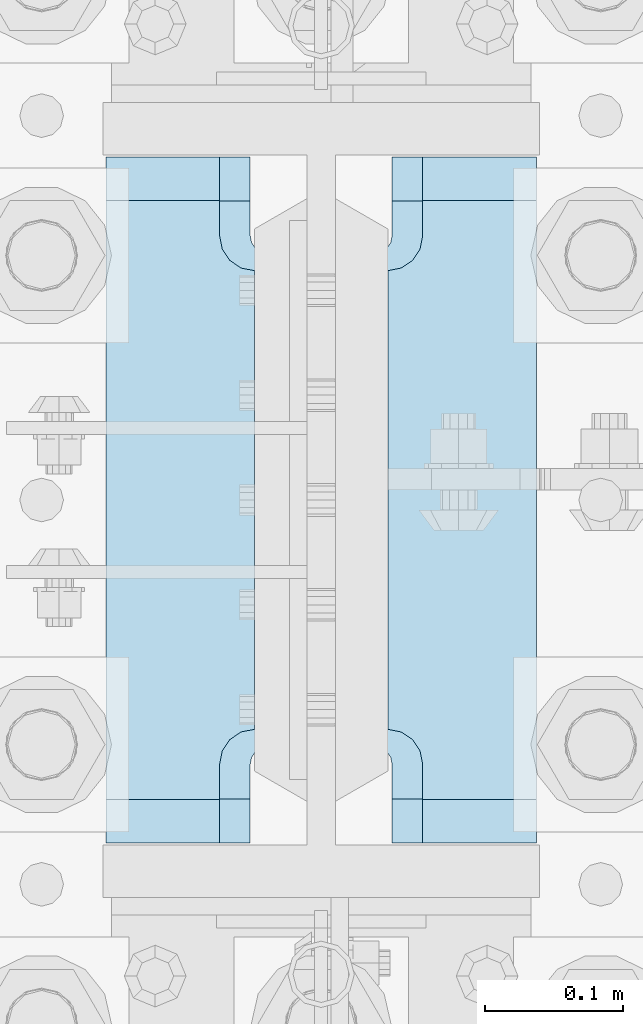
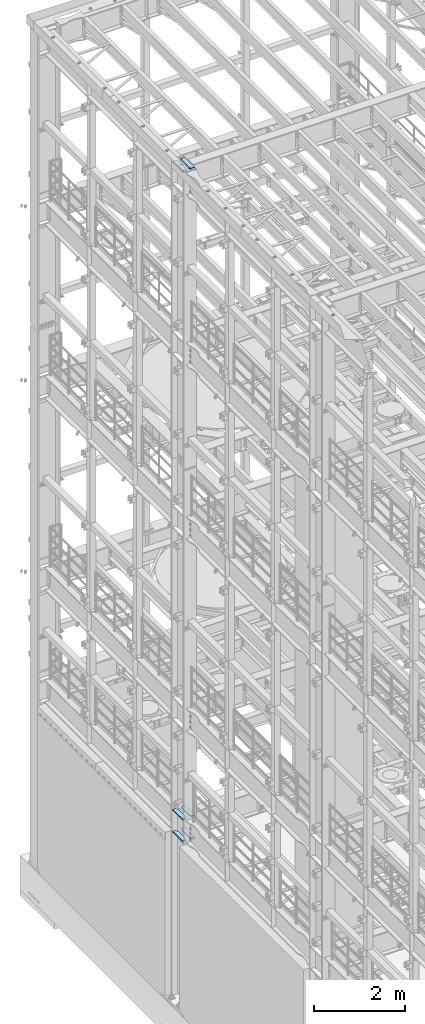
# One storey, part 1693 of 1876: 6 plates, 2 elements without a shape of their own.
"""IFC2X3 building model written with IfcOpenShell, lengths in millimetres."""

from ifc_helpers import new_model, si_unit, frame, origin_with_axes, place, context, subcontext, project, spatial, faceted_brep, material, type_object, element, aggregate, save


model = new_model("IFC2X3")

# Units and contexts
model_context = context("Model", 3, precision=1e-05, world=origin_with_axes())
body_context = subcontext(model_context, "Body", "Model", "MODEL_VIEW")
ifc_project = project(units=[si_unit("LENGTHUNIT", "METRE", prefix="MILLI"), si_unit("AREAUNIT", "SQUARE_METRE"), si_unit("VOLUMEUNIT", "CUBIC_METRE"), si_unit("MASSUNIT", "GRAM", prefix="KILO"), si_unit("TIMEUNIT", "SECOND"), si_unit("PLANEANGLEUNIT", "RADIAN"), si_unit("SOLIDANGLEUNIT", "STERADIAN"), si_unit("THERMODYNAMICTEMPERATUREUNIT", "DEGREE_CELSIUS"), si_unit("LUMINOUSINTENSITYUNIT", "LUMEN")], contexts=[model_context])

# Site, building, storey
site_placement = place(None, origin_with_axes())
site = spatial("IfcSite", under=ifc_project, at=site_placement, CompositionType="ELEMENT")
building_placement = place(site_placement, origin_with_axes())
building = spatial("IfcBuilding", under=site, at=building_placement, Name="Undefined", CompositionType="ELEMENT")
storey_placement = place(building_placement, origin_with_axes())
storey = spatial("IfcBuildingStorey", under=building, at=storey_placement, Name="Undefined", CompositionType="ELEMENT", Elevation=0.0)

# Assembly, plates
assembly_1_placement = place(storey_placement, origin_with_axes())
assembly_1 = element("IfcElementAssembly", 1, at=assembly_1_placement, inside=storey, Name="COLUMN", AssemblyPlace="NOTDEFINED", PredefinedType="RIGID_FRAME")
ifc_material = material(Name="STEEL/A572-50")
plate_type_1 = type_object("IfcPlateType", PredefinedType="NOTDEFINED")
plate_1_placement = place(assembly_1_placement, frame((-48.41875, 7370.7625, 4524.37501220703), z_axis=(0.0, 1.0, 0.0), x_axis=(-1.0, 0.0, 0.0)))
plate_1 = element("IfcPlate", 2, at=plate_1_placement, type_object=plate_type_1, material=ifc_material, Name="PLATE", context=body_context, shape_type="Brep", body=[
    faceted_brep([(107.949996948242, -15.875, 498.475006103516), (107.949996948242, 15.875, 467.025007631571), (25.3999996185303, 15.875, 467.025007631571), (25.3999996185303, -15.875, 498.475006103516), (23.4665397733561, -15.875, 431.604843634198), (25.3999996185303, -15.875, 441.325002670288), (25.3999996185303, 15.875, 441.325002670288), (23.4665397733561, 15.875, 431.604843634198), (17.9605119724001, -15.875, 423.36449069789), (17.9605119724001, 15.875, 423.36449069789), (9.72015903609281, -15.875, 417.858462896934), (9.72015903609281, 15.875, 417.858462896934), (0.0, -15.875, 415.925003051758), (0.0, 15.875, 415.925003051758), (0.0, -15.875, 82.5500030517578), (0.0, 15.875, 82.5500030517578), (9.72015903609099, -15.875, 80.616543206582), (9.72015903609099, 15.875, 80.616543206582), (17.9605119723983, -15.875, 75.1105154056258), (17.9605119723983, 15.875, 75.1105154056258), (23.4665397733552, -15.875, 66.8701624693183), (23.4665397733552, 15.875, 66.8701624693183), (25.3999996185303, -15.875, 57.1500034332275), (25.3999996185303, 15.875, 57.1500034332275), (25.3999996185303, 15.875, 31.449998471945), (25.3999996185303, -15.875, 0.0), (107.949996948242, 15.875, 31.449998471945), (107.949996948242, -15.875, 0.0)], [[[0, 1, 2, 3]], [[4, 5, 6, 7]], [[8, 4, 7, 9]], [[10, 8, 9, 11]], [[12, 10, 11, 13]], [[14, 12, 13, 15]], [[16, 14, 15, 17]], [[18, 16, 17, 19]], [[20, 18, 19, 21]], [[22, 20, 21, 23]], [[22, 23, 24, 25]], [[26, 27, 25, 24]], [[5, 4, 8, 10, 12, 14, 16, 18, 20, 22, 25, 27, 0, 3]], [[6, 5, 3, 2]], [[26, 24, 23, 21, 19, 17, 15, 13, 11, 9, 7, 6, 2, 1]], [[27, 26, 1, 0]]]),
])
plate_2_placement = place(assembly_1_placement, frame((-48.41875, 7370.7625, 5114.925), z_axis=(0.0, 1.0, 0.0), x_axis=(-1.0, 0.0, 0.0)))
plate_2 = element("IfcPlate", 3, at=plate_2_placement, type_object=plate_type_1, material=ifc_material, Name="PLATE", context=body_context, shape_type="Brep", body=[
    faceted_brep([(107.949996948242, -15.875, 498.475006103516), (107.949996948242, 15.875, 467.025007631571), (25.3999996185303, 15.875, 467.025007631571), (25.3999996185303, -15.875, 498.475006103516), (23.4665397733561, -15.875, 431.604843634198), (25.3999996185303, -15.875, 441.325002670288), (25.3999996185303, 15.875, 441.325002670288), (23.4665397733561, 15.875, 431.604843634198), (17.9605119724001, -15.875, 423.36449069789), (17.9605119724001, 15.875, 423.36449069789), (9.72015903609281, -15.875, 417.858462896934), (9.72015903609281, 15.875, 417.858462896934), (0.0, -15.875, 415.925003051758), (0.0, 15.875, 415.925003051758), (0.0, -15.875, 82.5500030517578), (0.0, 15.875, 82.5500030517578), (9.72015903609099, -15.875, 80.616543206582), (9.72015903609099, 15.875, 80.616543206582), (17.9605119723983, -15.875, 75.1105154056258), (17.9605119723983, 15.875, 75.1105154056258), (23.4665397733552, -15.875, 66.8701624693183), (23.4665397733552, 15.875, 66.8701624693183), (25.3999996185303, -15.875, 57.1500034332275), (25.3999996185303, 15.875, 57.1500034332275), (25.3999996185303, 15.875, 31.449998471945), (25.3999996185303, -15.875, 0.0), (107.949996948242, 15.875, 31.449998471945), (107.949996948242, -15.875, 0.0)], [[[0, 1, 2, 3]], [[4, 5, 6, 7]], [[8, 4, 7, 9]], [[10, 8, 9, 11]], [[12, 10, 11, 13]], [[14, 12, 13, 15]], [[16, 14, 15, 17]], [[18, 16, 17, 19]], [[20, 18, 19, 21]], [[22, 20, 21, 23]], [[22, 23, 24, 25]], [[26, 27, 25, 24]], [[5, 4, 8, 10, 12, 14, 16, 18, 20, 22, 25, 27, 0, 3]], [[6, 5, 3, 2]], [[26, 24, 23, 21, 19, 17, 15, 13, 11, 9, 7, 6, 2, 1]], [[27, 26, 1, 0]]]),
])
plate_3_placement = place(assembly_1_placement, frame((156.36875, 7370.7625, 4524.37501220703), z_axis=(0.0, 1.0, 0.0), x_axis=(-1.0, 0.0, 0.0)))
plate_3 = element("IfcPlate", 4, at=plate_3_placement, type_object=plate_type_1, material=ifc_material, Name="PLATE", context=body_context, shape_type="Brep", body=[
    faceted_brep([(82.5499973297119, -15.875, 498.475006103516), (82.5499973297119, 15.875, 467.025007631571), (0.0, 15.875, 467.025007631571), (0.0, -15.875, 498.475006103516), (82.5499973297119, 15.875, 31.449998471945), (82.5499973297119, -15.875, 0.0), (0.0, -15.875, 0.0), (0.0, 15.875, 31.449998471945), (82.5499973297119, 15.875, 57.1500034332275), (82.5499973297119, -15.875, 57.1500034332275), (84.4834571748879, -15.875, 66.8701624693188), (84.4834571748879, 15.875, 66.8701624693188), (89.9894849758439, -15.875, 75.1105154056261), (89.9894849758439, 15.875, 75.1105154056261), (98.2298379121512, -15.875, 80.616543206582), (98.2298379121512, 15.875, 80.616543206582), (107.949996948242, -15.875, 82.5500030517578), (107.949996948242, 15.875, 82.5500030517578), (107.949996948242, -15.875, 415.925003051758), (107.949996948242, 15.875, 415.925003051758), (98.2298379121512, -15.875, 417.858462896934), (98.2298379121512, 15.875, 417.858462896934), (89.9894849758439, -15.875, 423.36449069789), (89.9894849758439, 15.875, 423.36449069789), (84.483457174887, -15.875, 431.604843634197), (84.483457174887, 15.875, 431.604843634197), (82.5499973297119, -15.875, 441.325002670288), (82.5499973297119, 15.875, 441.325002670288)], [[[0, 1, 2, 3]], [[4, 5, 6, 7]], [[8, 9, 5, 4]], [[10, 9, 8, 11]], [[12, 10, 11, 13]], [[14, 12, 13, 15]], [[16, 14, 15, 17]], [[18, 16, 17, 19]], [[20, 18, 19, 21]], [[22, 20, 21, 23]], [[24, 22, 23, 25]], [[26, 24, 25, 27]], [[6, 5, 9, 10, 12, 14, 16, 18, 20, 22, 24, 26, 0, 3]], [[7, 6, 3, 2]], [[27, 25, 23, 21, 19, 17, 15, 13, 11, 8, 4, 7, 2, 1]], [[26, 27, 1, 0]]]),
])
plate_4_placement = place(assembly_1_placement, frame((156.36875, 7370.7625, 5114.925), z_axis=(0.0, 1.0, 0.0), x_axis=(-1.0, 0.0, 0.0)))
plate_4 = element("IfcPlate", 5, at=plate_4_placement, type_object=plate_type_1, material=ifc_material, Name="PLATE", context=body_context, shape_type="Brep", body=[
    faceted_brep([(82.5499973297119, -15.875, 498.475006103516), (82.5499973297119, 15.875, 467.025007631571), (0.0, 15.875, 467.025007631571), (0.0, -15.875, 498.475006103516), (82.5499973297119, 15.875, 31.449998471945), (82.5499973297119, -15.875, 0.0), (0.0, -15.875, 0.0), (0.0, 15.875, 31.449998471945), (82.5499973297119, 15.875, 57.1500034332275), (82.5499973297119, -15.875, 57.1500034332275), (84.4834571748879, -15.875, 66.8701624693188), (84.4834571748879, 15.875, 66.8701624693188), (89.9894849758439, -15.875, 75.1105154056261), (89.9894849758439, 15.875, 75.1105154056261), (98.2298379121512, -15.875, 80.616543206582), (98.2298379121512, 15.875, 80.616543206582), (107.949996948242, -15.875, 82.5500030517578), (107.949996948242, 15.875, 82.5500030517578), (107.949996948242, -15.875, 415.925003051758), (107.949996948242, 15.875, 415.925003051758), (98.2298379121512, -15.875, 417.858462896934), (98.2298379121512, 15.875, 417.858462896934), (89.9894849758439, -15.875, 423.36449069789), (89.9894849758439, 15.875, 423.36449069789), (84.483457174887, -15.875, 431.604843634197), (84.483457174887, 15.875, 431.604843634197), (82.5499973297119, -15.875, 441.325002670288), (82.5499973297119, 15.875, 441.325002670288)], [[[0, 1, 2, 3]], [[4, 5, 6, 7]], [[8, 9, 5, 4]], [[10, 9, 8, 11]], [[12, 10, 11, 13]], [[14, 12, 13, 15]], [[16, 14, 15, 17]], [[18, 16, 17, 19]], [[20, 18, 19, 21]], [[22, 20, 21, 23]], [[24, 22, 23, 25]], [[26, 24, 25, 27]], [[6, 5, 9, 10, 12, 14, 16, 18, 20, 22, 24, 26, 0, 3]], [[7, 6, 3, 2]], [[27, 25, 23, 21, 19, 17, 15, 13, 11, 8, 4, 7, 2, 1]], [[26, 27, 1, 0]]]),
])
aggregate(assembly_1, [plate_1, plate_2, plate_3, plate_4])

assembly_2_placement = place(storey_placement, origin_with_axes())
assembly_2 = element("IfcElementAssembly", 6, at=assembly_2_placement, inside=storey, Name="COLUMN", AssemblyPlace="NOTDEFINED", PredefinedType="RIGID_FRAME")
plate_type_2 = type_object("IfcPlateType", PredefinedType="NOTDEFINED")
plate_5_placement = place(assembly_2_placement, frame((-156.36875, 7370.7625, 22539.325), z_axis=(0.0, 1.0, 0.0), x_axis=(1.0, 0.0, 0.0)))
plate_5 = element("IfcPlate", 7, at=plate_5_placement, type_object=plate_type_2, material=ifc_material, Name="PLATE", context=body_context, shape_type="Brep", body=[
    faceted_brep([(108.494745348945, -15.875, 66.1302546510551), (108.494745348945, 15.875, 66.1302546510551), (112.614921817099, 15.875, 68.8832685515335), (112.614921817099, -15.875, 68.8832685515335), (105.741731448466, -15.875, 62.0100781829015), (105.741731448466, 15.875, 62.0100781829015), (104.775001525879, -15.875, 57.149998664856), (104.775001525879, 15.875, 57.149998664856), (104.775001525879, -15.875, 31.75), (104.775001525879, 15.875, 0.0), (0.0, -15.875, 31.75), (0.0, 15.875, 0.0), (0.0, -15.875, 466.725006103516), (0.0, 15.875, 498.475006103516), (104.775001525879, -15.875, 466.725006103516), (104.775001525879, 15.875, 498.475006103516), (104.775001525879, -15.875, 441.325001335143), (104.775001525879, 15.875, 441.325001335143), (105.741731448466, -15.875, 436.464921817097), (105.741731448466, 15.875, 436.464921817097), (108.494745348945, -15.875, 432.344745348943), (108.494745348945, 15.875, 432.344745348943), (112.614921817099, -15.875, 429.591731448465), (112.614921817099, 15.875, 429.591731448465), (117.475001335144, 15.875, 69.8499984741211), (117.475001335144, 15.875, 428.625001525877), (146.050003051758, 15.875, 428.625001525877), (146.050003051758, 15.875, 69.8499984741211), (117.475001335144, -12.7000017166138, 69.8499984741211), (114.300003051756, -15.875, 69.2184520491464), (114.300003051756, -15.875, 429.256547950852), (117.475001335144, -12.7000017166138, 428.625001525877)], [[[0, 1, 2, 3]], [[4, 5, 1, 0]], [[6, 7, 5, 4]], [[8, 9, 7, 6]], [[10, 11, 9, 8]], [[11, 10, 12, 13]], [[13, 12, 14, 15]], [[15, 14, 16, 17]], [[18, 19, 17, 16]], [[20, 21, 19, 18]], [[22, 23, 21, 20]], [[24, 2, 1, 5, 7, 9, 11, 13, 15, 17, 19, 21, 23, 25, 26, 27]], [[24, 27, 28]], [[3, 2, 24, 28, 29]], [[22, 20, 18, 16, 14, 12, 10, 8, 6, 4, 0, 3, 29, 30]], [[25, 23, 22, 30, 31]], [[25, 31, 26]], [[30, 29, 28, 27, 26, 31]]]),
])
plate_6_placement = place(assembly_2_placement, frame((156.36875, 7370.7625, 22539.325), z_axis=(0.0, 1.0, 0.0), x_axis=(-1.0, 0.0, 0.0)))
plate_6 = element("IfcPlate", 8, at=plate_6_placement, type_object=plate_type_2, material=ifc_material, Name="PLATE", context=body_context, shape_type="Brep", body=[
    faceted_brep([(108.494745348945, -15.875, 66.1302546510551), (108.494745348945, 15.875, 66.1302546510551), (112.614921817099, 15.875, 68.8832685515335), (112.614921817099, -15.875, 68.8832685515335), (105.741731448466, -15.875, 62.0100781829015), (105.741731448466, 15.875, 62.0100781829015), (104.775001525879, -15.875, 57.149998664856), (104.775001525879, 15.875, 57.149998664856), (104.775001525879, -15.875, 0.0), (104.775001525879, 15.875, 31.75), (0.0, -15.875, 0.0), (0.0, 15.875, 31.75), (0.0, -15.875, 498.475006103516), (0.0, 15.875, 466.725006103516), (104.775001525879, -15.875, 498.475006103516), (104.775001525879, 15.875, 466.725006103516), (104.775001525879, -15.875, 441.325001335143), (104.775001525879, 15.875, 441.325001335143), (105.741731448466, -15.875, 436.464921817097), (105.741731448466, 15.875, 436.464921817097), (108.494745348945, -15.875, 432.344745348943), (108.494745348945, 15.875, 432.344745348943), (112.614921817099, -15.875, 429.591731448465), (112.614921817099, 15.875, 429.591731448465), (117.475001335144, -15.875, 428.625001525877), (146.050003051758, -15.875, 428.625001525877), (117.475001335144, 12.6999956131003, 428.625001525877), (114.299996948243, 15.875, 429.256549164917), (114.299996948243, 15.875, 69.218450835082), (117.475001335144, -15.875, 69.8499984741211), (117.475001335144, 12.6999956131003, 69.8499984741211), (146.050003051758, -15.875, 69.8499984741211)], [[[0, 1, 2, 3]], [[4, 5, 1, 0]], [[6, 7, 5, 4]], [[8, 9, 7, 6]], [[10, 11, 9, 8]], [[11, 10, 12, 13]], [[13, 12, 14, 15]], [[14, 16, 17, 15]], [[18, 19, 17, 16]], [[20, 21, 19, 18]], [[22, 23, 21, 20]], [[24, 25, 26]], [[23, 22, 24, 26, 27]], [[2, 1, 5, 7, 9, 11, 13, 15, 17, 19, 21, 23, 27, 28]], [[29, 3, 2, 28, 30]], [[29, 30, 31]], [[24, 22, 20, 18, 16, 14, 12, 10, 8, 6, 4, 0, 3, 29, 31, 25]], [[30, 28, 27, 26, 25, 31]]]),
])
aggregate(assembly_2, [plate_5, plate_6])

save(model, "model.ifc")
